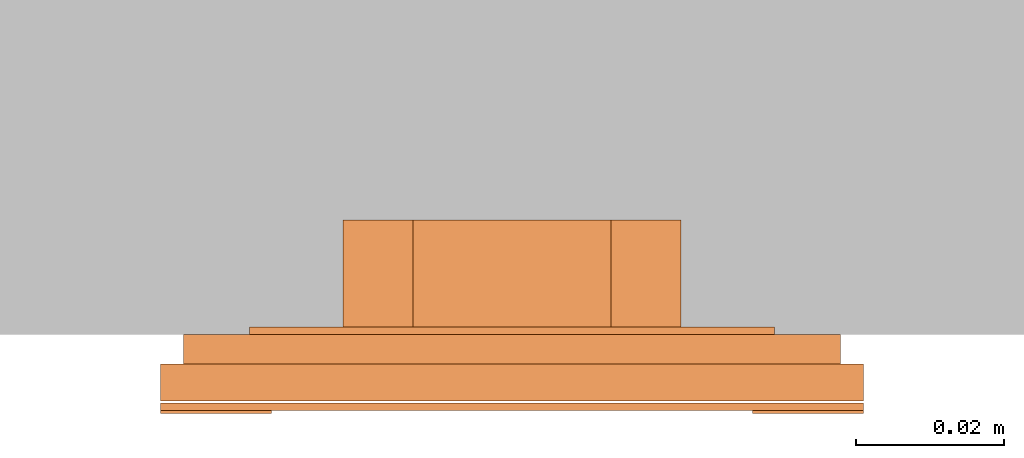
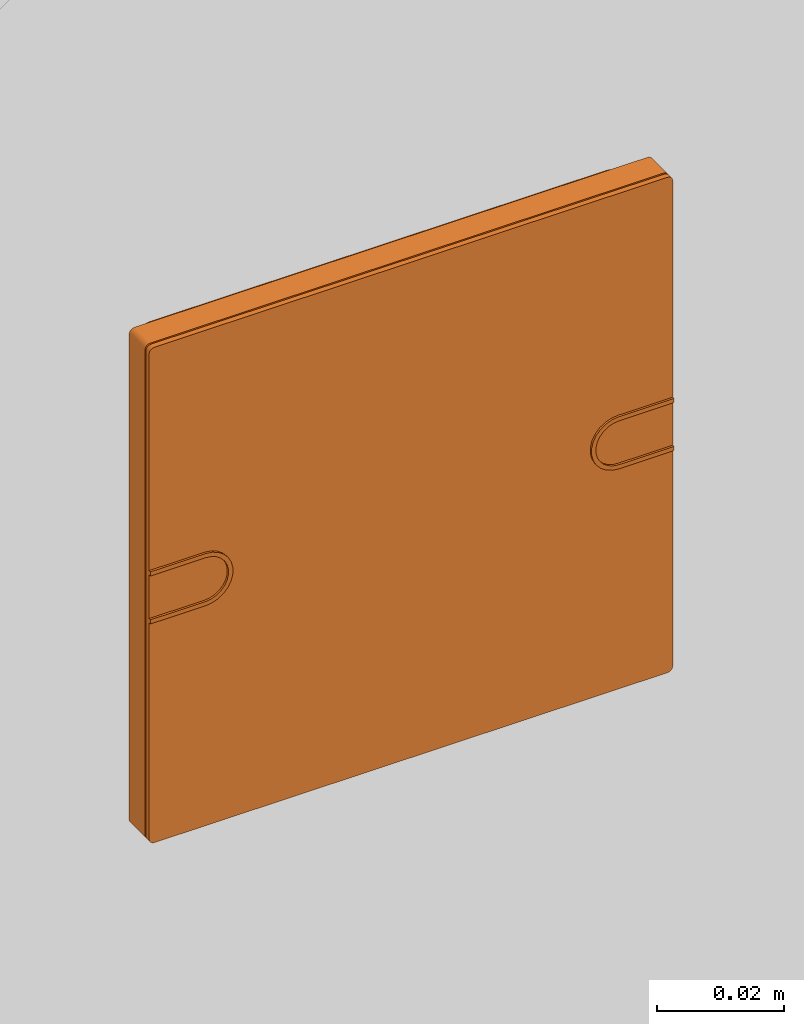
# One storey, part 2 of 2: 1 proxy.
"""IFC2X3 building model written with IfcOpenShell, lengths in metres."""

from ifc_helpers import new_model, entity, si_unit, converted_unit, derived_unit, direction, frame, frame_2d, origin, place, context, subcontext, project, spatial, polyline, circle_curve, parameter, trimmed, segment, composite_curve, outline, extrude, source, transform, mapped, material, type_object, type_shapes, element, save


model = new_model("IFC2X3")

# Units and contexts
model_context = context("Model", 3, precision=1e-05, world=origin(), true_north=direction((6.12303176911189e-17, 1.0)))
body_context = subcontext(model_context, "Body", "Model", "MODEL_VIEW")
ifc_project = project(units=[si_unit("LENGTHUNIT", "METRE"), si_unit("AREAUNIT", "SQUARE_METRE"), si_unit("VOLUMEUNIT", "CUBIC_METRE"), converted_unit("PLANEANGLEUNIT", "DEGREE", entity("IfcRatioMeasure", 0.0174532925199433), si_unit("PLANEANGLEUNIT", "RADIAN"), dimensions=[0, 0, 0, 0, 0, 0, 0]), si_unit("MASSUNIT", "GRAM", prefix="KILO"), si_unit("TIMEUNIT", "SECOND"), si_unit("FREQUENCYUNIT", "HERTZ"), si_unit("THERMODYNAMICTEMPERATUREUNIT", "DEGREE_CELSIUS"), derived_unit("THERMALTRANSMITTANCEUNIT", [(si_unit("MASSUNIT", "GRAM", prefix="KILO"), 1), (si_unit("THERMODYNAMICTEMPERATUREUNIT", "KELVIN"), -1), (si_unit("TIMEUNIT", "SECOND"), -3)]), derived_unit("VOLUMETRICFLOWRATEUNIT", [(si_unit("LENGTHUNIT", "METRE"), 3), (si_unit("TIMEUNIT", "SECOND"), -1)]), si_unit("ELECTRICCURRENTUNIT", "AMPERE"), si_unit("ELECTRICVOLTAGEUNIT", "VOLT"), si_unit("POWERUNIT", "WATT"), si_unit("FORCEUNIT", "NEWTON", prefix="KILO"), si_unit("ILLUMINANCEUNIT", "LUX"), si_unit("LUMINOUSFLUXUNIT", "LUMEN"), si_unit("LUMINOUSINTENSITYUNIT", "CANDELA"), derived_unit("USERDEFINED", [(si_unit("MASSUNIT", "GRAM", prefix="KILO"), -1), (si_unit("LENGTHUNIT", "METRE"), -2), (si_unit("TIMEUNIT", "SECOND"), 3), (si_unit("LUMINOUSFLUXUNIT", "LUMEN"), 1)]), derived_unit("LINEARVELOCITYUNIT", [(si_unit("LENGTHUNIT", "METRE"), 1), (si_unit("TIMEUNIT", "SECOND"), -1)]), si_unit("PRESSUREUNIT", "PASCAL"), derived_unit("USERDEFINED", [(si_unit("LENGTHUNIT", "METRE"), -2), (si_unit("MASSUNIT", "GRAM", prefix="KILO"), 1), (si_unit("TIMEUNIT", "SECOND"), -2)])], contexts=[model_context])

# Site, building, storey
site_placement = place(None, origin())
site = spatial("IfcSite", under=ifc_project, at=site_placement, CompositionType="ELEMENT")
building_placement = place(site_placement, origin())
building = spatial("IfcBuilding", under=site, at=building_placement, CompositionType="ELEMENT")
storey_placement = place(building_placement, origin())
storey = spatial("IfcBuildingStorey", under=building, at=storey_placement, Name="Ebene 0", CompositionType="ELEMENT", Elevation=0.0)

# Proxy
ifc_material = material(Name="White")
building_element_proxy_type = type_object("IfcBuildingElementProxyType", PredefinedType="NOTDEFINED", material=ifc_material)
shared_shape = source(origin(), body_context, "Body", "SweptSolid", [
    extrude(outline(composite_curve([segment(polyline([(-0.00499999999999999, -0.00499999999999998), (-0.0042, -0.00499999999999998)]), True, "CONTINUOUS"), segment(polyline([(-0.0042, -0.00499999999999998), (-0.00420000000000001, 0.00499999999999998)]), True, "CONTINUOUS"), segment(trimmed(circle_curve(frame_2d((0.0, 0.00500000000000001), x_axis=(0.0, 1.0)), 0.00420000000000002), [parameter(270.0)], [parameter(90.0000000000005)], True, "PARAMETER"), False, "CONTINUOUS"), segment(polyline([(0.00420000000000002, 0.00500000000000004), (0.0042, -0.00499999999999998)]), True, "CONTINUOUS"), segment(polyline([(0.0042, -0.00499999999999998), (0.00499999999999999, -0.00499999999999998)]), True, "CONTINUOUS"), segment(polyline([(0.00499999999999999, -0.00499999999999998), (0.00500000000000001, 0.00500000000000003)]), True, "CONTINUOUS"), segment(trimmed(circle_curve(frame_2d((0.0, 0.005), x_axis=(0.0, 1.0)), 0.00500000000000001), [parameter(270.0)], [parameter(90.0000000000002)], True, "PARAMETER"), True, "CONTINUOUS"), segment(polyline([(-0.00500000000000002, 0.00499999999999999), (-0.00499999999999999, -0.00499999999999998)]), True, "CONTINUOUS")], self_intersect=False)), frame((-0.0424999999999938, 0.0, 0.00949999999999813), z_axis=(0.0, 0.0, 1.0), x_axis=(0.0, -1.0, 0.0)), (0.0, 0.0, 1.0), 0.0012),
    extrude(outline(composite_curve([segment(polyline([(-0.00499999999999996, -0.00500000000000001), (0.00500000000000001, -0.00500000000000001)]), True, "CONTINUOUS"), segment(trimmed(circle_curve(frame_2d((0.005, 0.0), x_axis=(1.0, 0.0)), 0.00500000000000001), [parameter(269.999999999999)], [parameter(89.9999999999997)], True, "PARAMETER"), True, "CONTINUOUS"), segment(polyline([(0.00500000000000002, 0.00500000000000002), (-0.00499999999999999, 0.00499999999999998)]), True, "CONTINUOUS"), segment(polyline([(-0.00499999999999999, 0.00499999999999998), (-0.00499999999999999, 0.00419999999999999)]), True, "CONTINUOUS"), segment(polyline([(-0.00499999999999999, 0.00419999999999999), (0.00500000000000002, 0.00420000000000003)]), True, "CONTINUOUS"), segment(trimmed(circle_curve(frame_2d((0.00500000000000001, 0.0), x_axis=(1.0, 0.0)), 0.00420000000000002), [parameter(270.0)], [parameter(90.0000000000002)], True, "PARAMETER"), False, "CONTINUOUS"), segment(polyline([(0.00499999999999999, -0.0042), (-0.00499999999999997, -0.00420000000000001)]), True, "CONTINUOUS"), segment(polyline([(-0.00499999999999997, -0.00420000000000001), (-0.00499999999999996, -0.00500000000000001)]), True, "CONTINUOUS")], self_intersect=False)), frame((0.0425000000000063, 0.0, 0.00949999999999813), z_axis=(0.0, 0.0, 1.0), x_axis=(-1.0, 0.0, 0.0)), (0.0, 0.0, 1.0), 0.0012),
    extrude(outline(composite_curve([segment(trimmed(circle_curve(frame_2d((-0.0465000000000125, 0.0465000000000168), x_axis=(1.0, 0.0)), 0.001), [parameter(90.0000000000003)], [parameter(180.0)], True, "PARAMETER"), True, "CONTINUOUS"), segment(polyline([(-0.0475000000000125, 0.0465000000000168), (-0.0475000000000125, -0.0465000000000169)]), True, "CONTINUOUS"), segment(trimmed(circle_curve(frame_2d((-0.0465000000000125, -0.0465000000000169), x_axis=(-1.0, 0.0)), 0.001), [parameter(0.0)], [parameter(90.0000000000001)], True, "PARAMETER"), True, "CONTINUOUS"), segment(polyline([(-0.0465000000000125, -0.0475000000000169), (0.0465000000000127, -0.0475000000000166)]), True, "CONTINUOUS"), segment(trimmed(circle_curve(frame_2d((0.0465000000000127, -0.0465000000000166), x_axis=(-1.0, 0.0)), 0.001), [parameter(90.0000000000011)], [parameter(179.999999999999)], True, "PARAMETER"), True, "CONTINUOUS"), segment(polyline([(0.0475000000000127, -0.0465000000000166), (0.0475000000000124, 0.0465000000000168)]), True, "CONTINUOUS"), segment(trimmed(circle_curve(frame_2d((0.0465000000000124, 0.0465000000000168), x_axis=(-1.0, 0.0)), 0.001), [parameter(180.0)], [parameter(269.999999999999)], True, "PARAMETER"), True, "CONTINUOUS"), segment(polyline([(0.0465000000000124, 0.0475000000000168), (-0.0465000000000125, 0.0475000000000168)]), True, "CONTINUOUS")], self_intersect=False)), frame((0.0, 0.0, 0.00929999999999813), z_axis=(0.0, 0.0, 1.0), x_axis=(-1.0, 0.0, 0.0)), (0.0, 0.0, 1.0), 0.001),
    extrude(outline(composite_curve([segment(trimmed(circle_curve(frame_2d((-0.0465000000000125, 0.0465000000000168), x_axis=(1.0, 0.0)), 0.001), [parameter(90.0000000000003)], [parameter(180.0)], True, "PARAMETER"), True, "CONTINUOUS"), segment(polyline([(-0.0475000000000125, 0.0465000000000168), (-0.0475000000000125, -0.0465000000000169)]), True, "CONTINUOUS"), segment(trimmed(circle_curve(frame_2d((-0.0465000000000125, -0.0465000000000169), x_axis=(-1.0, 0.0)), 0.001), [parameter(0.0)], [parameter(90.0000000000001)], True, "PARAMETER"), True, "CONTINUOUS"), segment(polyline([(-0.0465000000000125, -0.0475000000000169), (0.0465000000000127, -0.0475000000000166)]), True, "CONTINUOUS"), segment(trimmed(circle_curve(frame_2d((0.0465000000000127, -0.0465000000000166), x_axis=(-1.0, 0.0)), 0.001), [parameter(90.0000000000011)], [parameter(179.999999999999)], True, "PARAMETER"), True, "CONTINUOUS"), segment(polyline([(0.0475000000000127, -0.0465000000000166), (0.0475000000000124, 0.0465000000000168)]), True, "CONTINUOUS"), segment(trimmed(circle_curve(frame_2d((0.0465000000000124, 0.0465000000000168), x_axis=(-1.0, 0.0)), 0.001), [parameter(180.0)], [parameter(269.999999999999)], True, "PARAMETER"), True, "CONTINUOUS"), segment(polyline([(0.0465000000000124, 0.0475000000000168), (-0.0465000000000125, 0.0475000000000168)]), True, "CONTINUOUS")], self_intersect=False)), frame((0.0, 0.0, 0.00399999999999813), z_axis=(0.0, 0.0, 1.0), x_axis=(-1.0, 0.0, 0.0)), (0.0, 0.0, 1.0), 0.005),
    extrude(outline(composite_curve([segment(polyline([(-0.0413999999999997, -0.0443999999999999), (0.0414, -0.0443999999999999)]), True, "CONTINUOUS"), segment(trimmed(circle_curve(frame_2d((0.0414, -0.0413999999999999), x_axis=(-1.0, 0.0)), 0.003), [parameter(89.9999999999998)], [parameter(180.0)], True, "PARAMETER"), True, "CONTINUOUS"), segment(polyline([(0.0444, -0.0413999999999999), (0.0444, 0.0414000000000002)]), True, "CONTINUOUS"), segment(trimmed(circle_curve(frame_2d((0.0414, 0.0414000000000001), x_axis=(-1.0, 0.0)), 0.003), [parameter(180.0)], [parameter(270.0)], True, "PARAMETER"), True, "CONTINUOUS"), segment(polyline([(0.0414, 0.0444000000000001), (-0.0414000000000003, 0.0443999999999996)]), True, "CONTINUOUS"), segment(trimmed(circle_curve(frame_2d((-0.0414000000000003, 0.0413999999999996), x_axis=(-1.0, 0.0)), 0.003), [parameter(270.0)], [parameter(1.52666624710249e-13)], True, "PARAMETER"), True, "CONTINUOUS"), segment(polyline([(-0.0444000000000003, 0.0413999999999996), (-0.0443999999999997, -0.0413999999999999)]), True, "CONTINUOUS"), segment(trimmed(circle_curve(frame_2d((-0.0413999999999997, -0.0413999999999999), x_axis=(-1.0, 0.0)), 0.003), [parameter(0.0)], [parameter(89.9999999999998)], True, "PARAMETER"), True, "CONTINUOUS")], self_intersect=False), holes=[composite_curve([segment(trimmed(circle_curve(frame_2d((0.0414, 0.0414000000000001), x_axis=(-1.0, 0.0)), 0.001), [parameter(180.000000000001)], [parameter(270.0)], True, "PARAMETER"), False, "CONTINUOUS"), segment(polyline([(0.0424, 0.0414000000000001), (0.0424, -0.0413999999999999)]), True, "CONTINUOUS"), segment(trimmed(circle_curve(frame_2d((0.0414, -0.0413999999999999), x_axis=(-1.0, 0.0)), 0.001), [parameter(90.0000000000005)], [parameter(180.0)], True, "PARAMETER"), False, "CONTINUOUS"), segment(polyline([(0.0414, -0.0423999999999999), (-0.0413999999999997, -0.0423999999999999)]), True, "CONTINUOUS"), segment(trimmed(circle_curve(frame_2d((-0.0413999999999997, -0.0413999999999999), x_axis=(-1.0, 0.0)), 0.001), [parameter(5.08888749034163e-13)], [parameter(90.0000000000001)], True, "PARAMETER"), False, "CONTINUOUS"), segment(polyline([(-0.0423999999999997, -0.0413999999999999), (-0.0424000000000003, 0.0413999999999996)]), True, "CONTINUOUS"), segment(trimmed(circle_curve(frame_2d((-0.0414000000000003, 0.0413999999999996), x_axis=(-1.0, 0.0)), 0.001), [parameter(270.0)], [parameter(5.08888749034163e-13)], True, "PARAMETER"), False, "CONTINUOUS"), segment(polyline([(-0.0414000000000003, 0.0423999999999996), (0.0414, 0.0424000000000001)]), True, "CONTINUOUS")], self_intersect=False)]), frame((0.0, 0.0, 0.0), z_axis=(0.0, 0.0, 1.0), x_axis=(-1.0, 0.0, 0.0)), (0.0, 0.0, 1.0), 0.004),
    extrude(outline(composite_curve([segment(trimmed(circle_curve(frame_2d((-0.02545, 0.02545), x_axis=(1.0, 0.0)), 0.01), [parameter(90.0000000000001)], [parameter(180.0)], True, "PARAMETER"), True, "CONTINUOUS"), segment(polyline([(-0.03545, 0.0254500000000001), (-0.03545, -0.0254500000000001)]), True, "CONTINUOUS"), segment(trimmed(circle_curve(frame_2d((-0.02545, -0.02545), x_axis=(1.0, 0.0)), 0.01), [parameter(180.0)], [parameter(270.0)], True, "PARAMETER"), True, "CONTINUOUS"), segment(polyline([(-0.0254500000000001, -0.03545), (0.02545, -0.03545)]), True, "CONTINUOUS"), segment(trimmed(circle_curve(frame_2d((0.02545, -0.02545), x_axis=(-1.0, 0.0)), 0.01), [parameter(90.0000000000001)], [parameter(180.0)], True, "PARAMETER"), True, "CONTINUOUS"), segment(polyline([(0.03545, -0.02545), (0.03545, 0.02545)]), True, "CONTINUOUS"), segment(trimmed(circle_curve(frame_2d((0.02545, 0.02545), x_axis=(-1.0, 0.0)), 0.01), [parameter(180.0)], [parameter(270.0)], True, "PARAMETER"), True, "CONTINUOUS"), segment(polyline([(0.0254500000000001, 0.03545), (-0.0254500000000001, 0.03545)]), True, "CONTINUOUS")], self_intersect=False), holes=[composite_curve([segment(trimmed(circle_curve(frame_2d((-0.0270821897194447, 0.0299106168441909), x_axis=(1.0, 0.0)), 0.00200000000000001), [parameter(315.0)], [parameter(135.0)], True, "PARAMETER"), False, "CONTINUOUS"), segment(polyline([(-0.0256679761570716, 0.0284964032818178), (-0.0284964032818178, 0.0256679761570716)]), True, "CONTINUOUS"), segment(trimmed(circle_curve(frame_2d((-0.0299106168441909, 0.0270821897194447), x_axis=(1.0, 0.0)), 0.002), [parameter(135.000000000001)], [parameter(315.0)], True, "PARAMETER"), False, "CONTINUOUS"), segment(polyline([(-0.031324830406564, 0.0284964032818178), (-0.0284964032818178, 0.031324830406564)]), True, "CONTINUOUS")], self_intersect=False), composite_curve([segment(trimmed(circle_curve(frame_2d((-0.0299106168440928, -0.0270821897195872), x_axis=(0.0, 1.0)), 0.00200000000000001), [parameter(315.0)], [parameter(135.000000000001)], True, "PARAMETER"), False, "CONTINUOUS"), segment(polyline([(-0.0284964032817251, -0.0256679761572088), (-0.0256679761569682, -0.0284964032819443)]), True, "CONTINUOUS"), segment(trimmed(circle_curve(frame_2d((-0.0270821897193359, -0.0299106168443227), x_axis=(0.0, 1.0)), 0.002), [parameter(135.0)], [parameter(315.0)], True, "PARAMETER"), False, "CONTINUOUS"), segment(polyline([(-0.0284964032817037, -0.0313248304067012), (-0.0313248304064606, -0.0284964032819657)]), True, "CONTINUOUS")], self_intersect=False), composite_curve([segment(polyline([(0.0284964032818178, 0.031324830406564), (0.031324830406564, 0.0284964032818178)]), True, "CONTINUOUS"), segment(trimmed(circle_curve(frame_2d((0.0299106168441909, 0.0270821897194447), x_axis=(-1.0, 0.0)), 0.002), [parameter(45.0000000000004)], [parameter(225.0)], True, "PARAMETER"), False, "CONTINUOUS"), segment(polyline([(0.0284964032818178, 0.0256679761570716), (0.0256679761570716, 0.0284964032818178)]), True, "CONTINUOUS"), segment(trimmed(circle_curve(frame_2d((0.0270821897194447, 0.0299106168441909), x_axis=(-1.0, 0.0)), 0.00200000000000001), [parameter(225.0)], [parameter(44.9999999999999)], True, "PARAMETER"), False, "CONTINUOUS")], self_intersect=False), composite_curve([segment(polyline([(0.0313248304064606, -0.0284964032819657), (0.0284964032817037, -0.0313248304067012)]), True, "CONTINUOUS"), segment(trimmed(circle_curve(frame_2d((0.0270821897193359, -0.0299106168443227), x_axis=(0.0, 1.0)), 0.002), [parameter(45.0000000000003)], [parameter(225.0)], True, "PARAMETER"), False, "CONTINUOUS"), segment(polyline([(0.0256679761569682, -0.0284964032819443), (0.0284964032817251, -0.0256679761572088)]), True, "CONTINUOUS"), segment(trimmed(circle_curve(frame_2d((0.0299106168440928, -0.0270821897195872), x_axis=(0.0, 1.0)), 0.00200000000000001), [parameter(225.0)], [parameter(45.0)], True, "PARAMETER"), False, "CONTINUOUS")], self_intersect=False), polyline([(0.0133901883561006, 0.022831011754894), (0.022831011754894, 0.0133901883561005), (0.022831011754894, -0.0133901883561007), (0.0133901883561006, -0.022831011754894), (-0.0133901883561006, -0.022831011754894), (-0.022831011754894, -0.0133901883561006), (-0.022831011754894, 0.0133901883561006), (-0.0133901883561006, 0.022831011754894), (0.0133901883561006, 0.022831011754894)]), composite_curve([segment(trimmed(circle_curve(frame_2d((-0.00377680189852487, 0.029788004180913), x_axis=(1.0, 0.0)), 0.0029), [parameter(43.7312395648615)], [parameter(324.455810783523)], True, "PARAMETER"), False, "CONTINUOUS"), segment(trimmed(circle_curve(frame_2d((0.00020313886723953, 0.00221282045422128), x_axis=(1.0, 0.0)), 0.0296398498895369), [parameter(78.5704662642775)], [parameter(93.645183270812)], True, "PARAMETER"), False, "CONTINUOUS"), segment(trimmed(circle_curve(frame_2d((0.0057098792346926, 0.0294507398536438), x_axis=(1.0, 0.0)), 0.0018508512986561), [parameter(270.948014931406)], [parameter(78.5704662642829)], True, "PARAMETER"), False, "CONTINUOUS"), segment(trimmed(circle_curve(frame_2d((0.000198292327786931, -0.000143073394859841), x_axis=(1.0, 0.0)), 0.0282913782444803), [parameter(78.7028434483939)], [parameter(93.2734120855582)], True, "PARAMETER"), True, "CONTINUOUS")], self_intersect=False), composite_curve([segment(trimmed(circle_curve(frame_2d((0.00377680189854983, -0.0297880041809467), x_axis=(-1.0, 0.0)), 0.0029), [parameter(43.7312395648614)], [parameter(324.455810783523)], True, "PARAMETER"), False, "CONTINUOUS"), segment(trimmed(circle_curve(frame_2d((-0.000203138867214483, -0.00221282045425497), x_axis=(-1.0, 0.0)), 0.0296398498895369), [parameter(78.5704662642775)], [parameter(93.645183270812)], True, "PARAMETER"), False, "CONTINUOUS"), segment(trimmed(circle_curve(frame_2d((-0.00570987923466764, -0.0294507398536775), x_axis=(-1.0, 0.0)), 0.0018508512986561), [parameter(270.948014931407)], [parameter(78.5704662642829)], True, "PARAMETER"), False, "CONTINUOUS"), segment(trimmed(circle_curve(frame_2d((-0.000198292327761875, 0.000143073394826152), x_axis=(-1.0, 0.0)), 0.0282913782444803), [parameter(78.7028434483939)], [parameter(93.2734120855582)], True, "PARAMETER"), True, "CONTINUOUS")], self_intersect=False), composite_curve([segment(trimmed(circle_curve(frame_2d((-0.0297880041809172, -0.00377680189855411), x_axis=(0.0, 1.0)), 0.0029), [parameter(43.7312395648614)], [parameter(324.455810783523)], True, "PARAMETER"), False, "CONTINUOUS"), segment(trimmed(circle_curve(frame_2d((-0.00221282045422552, 0.00020313886721024), x_axis=(0.0, 1.0)), 0.0296398498895369), [parameter(78.5704662642775)], [parameter(93.645183270812)], True, "PARAMETER"), False, "CONTINUOUS"), segment(trimmed(circle_curve(frame_2d((-0.0294507398536481, 0.00570987923466336), x_axis=(0.0, 1.0)), 0.0018508512986561), [parameter(270.948014931407)], [parameter(78.5704662642829)], True, "PARAMETER"), False, "CONTINUOUS"), segment(trimmed(circle_curve(frame_2d((0.000143073394855601, 0.000198292327757636), x_axis=(0.0, 1.0)), 0.0282913782444803), [parameter(78.702843448394)], [parameter(93.2734120855582)], True, "PARAMETER"), True, "CONTINUOUS")], self_intersect=False), composite_curve([segment(trimmed(circle_curve(frame_2d((0.0297880041809424, 0.00377680189852048), x_axis=(0.0, -1.0)), 0.0029), [parameter(43.7312395648607)], [parameter(324.455810783523)], True, "PARAMETER"), False, "CONTINUOUS"), segment(trimmed(circle_curve(frame_2d((0.00221282045425073, -0.000203138867243781), x_axis=(0.0, -1.0)), 0.0296398498895369), [parameter(78.5704662642775)], [parameter(93.645183270812)], True, "PARAMETER"), False, "CONTINUOUS"), segment(trimmed(circle_curve(frame_2d((0.0294507398536733, -0.00570987923469698), x_axis=(0.0, -1.0)), 0.0018508512986561), [parameter(270.948014931407)], [parameter(78.5704662642836)], True, "PARAMETER"), False, "CONTINUOUS"), segment(trimmed(circle_curve(frame_2d((-0.000143073394830393, -0.000198292327791169), x_axis=(0.0, -1.0)), 0.0282913782444803), [parameter(78.702843448394)], [parameter(93.2734120855582)], True, "PARAMETER"), True, "CONTINUOUS")], self_intersect=False)]), frame((0.0, 0.0, -0.00100000000000187)), (0.0, 0.0, 1.0), 0.001),
    extrude(outline(polyline([(-0.00667567024527144, -0.0256122562211992), (0.00667567024527142, -0.0256122562211992), (0.0256122562211992, -0.00667567024527147), (0.0256122562211992, 0.00667567024527142), (0.00667567024527143, 0.0256122562211992), (-0.00667567024527141, 0.0256122562211992), (-0.0256122562211992, 0.00667567024527147), (-0.0256122562211992, -0.00667567024527143), (-0.00667567024527144, -0.0256122562211992)])), frame((0.0, 0.0, -0.0155000000000019), z_axis=(0.0, 0.0, 1.0), x_axis=(-0.707106781186548, -0.707106781186547, 0.0)), (0.0, 0.0, 1.0), 0.0155),
])
type_shapes(building_element_proxy_type, [shared_shape])
proxy_placement = place(storey_placement, frame((-7.3192018927039, -2.38240134987377, 1.46476426472422), z_axis=(0.0, -1.0, 0.0), x_axis=(1.0, 0.0, 0.0)))
element("IfcBuildingElementProxy", 1, at=proxy_placement, inside=storey, type_object=building_element_proxy_type, material=ifc_material, context=body_context, shape_type="MappedRepresentation", body=[
    mapped(shared_shape, transform((0.0, 0.0, 0.0), scale=1.0)),
])

save(model, "model.ifc")
